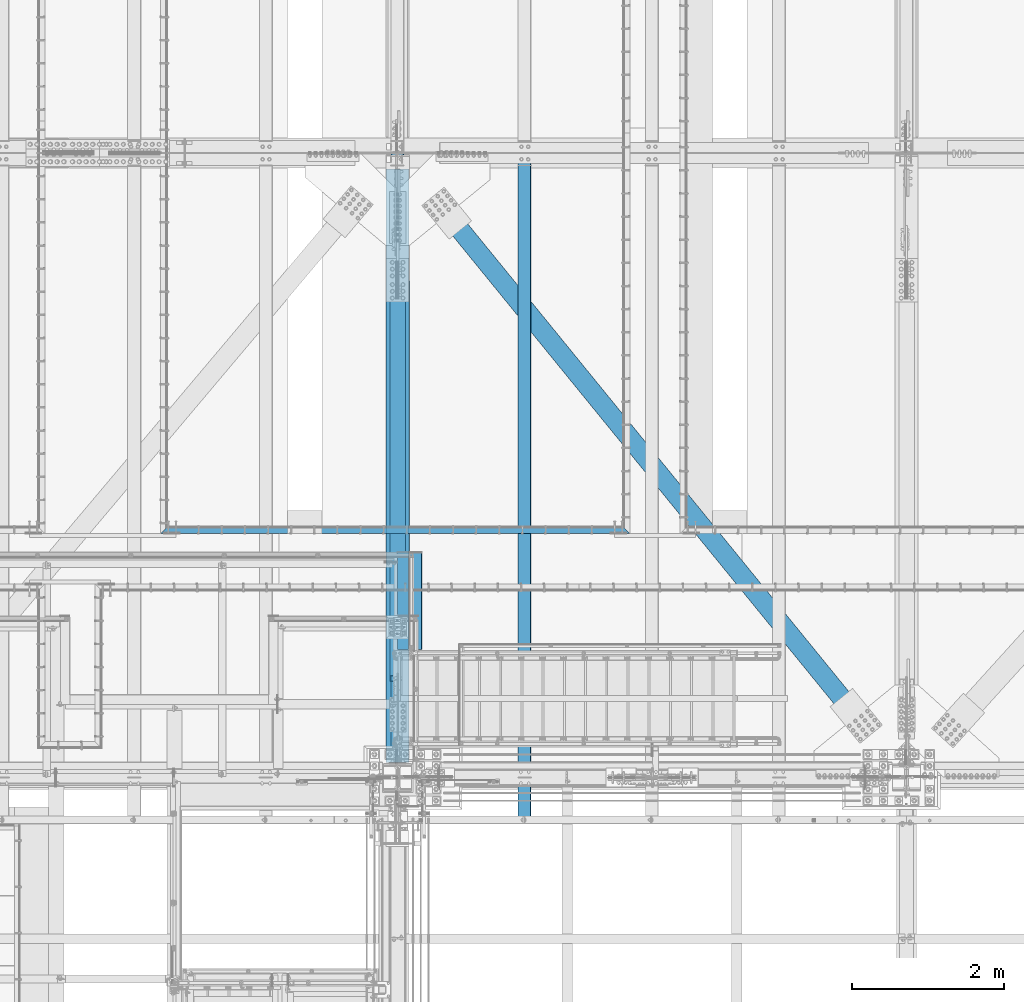
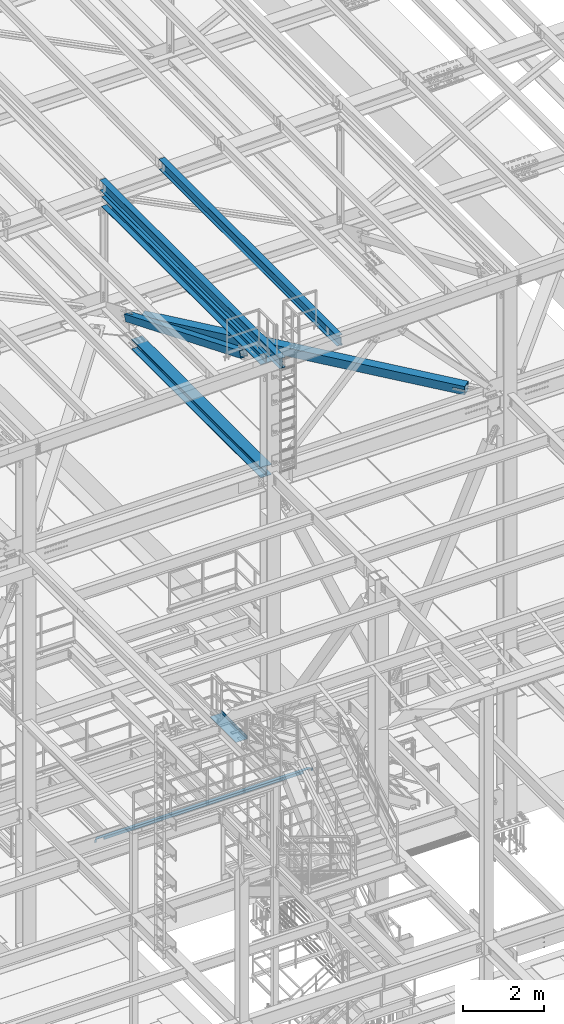
# One storey, part 1791 of 3843: 7 beams, 1 member, 8 elements without a shape of their own.
"""IFC2X3 building model written with IfcOpenShell, lengths in millimetres."""

from ifc_helpers import new_model, si_unit, frame, origin_with_axes, place, context, subcontext, project, spatial, faceted_brep, material, type_object, element, aggregate, save


model = new_model("IFC2X3")

# Units and contexts
model_context = context("Model", 3, precision=1e-05, world=origin_with_axes())
body_context = subcontext(model_context, "Body", "Model", "MODEL_VIEW")
ifc_project = project(units=[si_unit("LENGTHUNIT", "METRE", prefix="MILLI"), si_unit("AREAUNIT", "SQUARE_METRE"), si_unit("VOLUMEUNIT", "CUBIC_METRE"), si_unit("MASSUNIT", "GRAM", prefix="KILO"), si_unit("TIMEUNIT", "SECOND"), si_unit("PLANEANGLEUNIT", "RADIAN"), si_unit("SOLIDANGLEUNIT", "STERADIAN"), si_unit("THERMODYNAMICTEMPERATUREUNIT", "DEGREE_CELSIUS"), si_unit("LUMINOUSINTENSITYUNIT", "LUMEN")], contexts=[model_context])

# Site, building, storey
site_placement = place(None, origin_with_axes())
site = spatial("IfcSite", under=ifc_project, at=site_placement, CompositionType="ELEMENT")
building_placement = place(site_placement, origin_with_axes())
building = spatial("IfcBuilding", under=site, at=building_placement, Name="Undefined", CompositionType="ELEMENT")
storey_placement = place(building_placement, origin_with_axes())
storey = spatial("IfcBuildingStorey", under=building, at=storey_placement, Name="Undefined", CompositionType="ELEMENT", Elevation=0.0)

# Assembly, beam
assembly_1_placement = place(storey_placement, origin_with_axes())
assembly_1 = element("IfcElementAssembly", 1, at=assembly_1_placement, inside=storey, Name="EMBED_ANGLE", AssemblyPlace="NOTDEFINED", PredefinedType="RIGID_FRAME")
ifc_material_1 = material(Name="STEEL/A36")
beam_type_1 = type_object("IfcBeamType", Name="L3-1/2X3-1/2X5/16", PredefinedType="NOTDEFINED")
beam_1_placement = place(assembly_1_placement, frame((52807.362, 28873.45, 30410.15), z_axis=(0.0, 0.0, -1.0), x_axis=(1.0, 0.0, 0.0)))
beam_1 = element("IfcBeam", 2, at=beam_1_placement, type_object=beam_type_1, material=ifc_material_1, Name="EMBED_ANGLE", ObjectType="L3-1/2X3-1/2X5/16", context=body_context, shape_type="Brep", body=[
    faceted_brep([(44.4497890624625, 36.5125000000007, 44.4500000000007), (44.4497890624625, 36.5125000000007, -36.5125000000007), (44.4497890624625, 44.4500000000007, -36.5124999999971), (44.4497890624625, 44.4500000000007, 44.4500000000007), (260.349789062486, 36.5125000000007, -36.5125000000007), (260.349789062486, 44.4500000000007, -36.5125000000007), (260.349789062486, 36.5125000000007, 44.4499999999898), (260.349789062486, 44.4500000000007, 44.4500000000007), (6177.02586035159, 36.5125000000007, 44.4500000000007), (6184.96336035159, 44.4500000000007, 44.4500000000007), (6140.44980468748, 44.4500000000007, 44.4500000000007), (6140.44980468748, 36.5125000000007, 44.4499999999862), (5924.54980468746, 36.5125000000007, -36.5125000000007), (5924.54980468746, 36.5125000000007, 44.4500000000007), (5924.54980468746, 44.4500000000007, -36.5125000000007), (5924.54980468746, 44.4500000000007, 44.4500000000007), (6140.44980468748, 36.5125000000007, -36.5125000000007), (6140.44980468748, 44.4500000000007, -36.5125000000044), (6177.02586035159, 36.5125000000007, -36.5125000000007), (5924.54980468746, -44.4500000000007, -36.5125000000007), (260.349789062486, -44.4500000000007, -36.5125000000007), (88.8989646580376, -44.4500000000007, -36.5125000000007), (88.8989646580376, -44.4500000000007, -44.4500000000007), (6096.06336035159, -44.4500000000007, -44.4500000000007), (6096.06336035159, -44.4500000000007, -36.5125000000007), (44.4497890624625, -0.000305424058751669, -36.5125000000007), (7.93740995020198, 36.5125000000007, -36.5125000000007), (7.93740995020198, 36.5125000000007, 44.4500000000007), (-3.63797880709171e-12, 44.4499999999971, 44.4500000000007), (-3.63797880709171e-12, 44.4499999999971, -44.4500000000007), (6184.96336035159, 44.4500000000007, -44.4500000000007), (6140.44980468748, -0.0635556641136645, -36.5125000000007)], [[[0, 1, 2, 3]], [[4, 5, 2, 1]], [[6, 7, 5, 4]], [[8, 9, 10, 11]], [[12, 13, 6, 4]], [[13, 12, 14, 15]], [[16, 17, 14, 12]], [[11, 10, 17, 16]], [[18, 8, 11, 16]], [[19, 20, 21, 22, 23, 24]], [[22, 21, 25, 26, 27, 28, 29]], [[22, 29, 30, 23]], [[8, 18, 31, 24, 23, 30, 9]], [[16, 12, 4, 1, 26, 25, 21, 20, 19, 24, 31, 18]], [[27, 26, 1, 0]], [[28, 27, 0, 3]], [[15, 14, 17, 10, 9, 30, 29, 28, 3, 2, 5, 7]], [[13, 15, 7, 6]]]),
])
aggregate(assembly_1, [beam_1])

assembly_2_placement = place(storey_placement, origin_with_axes())
assembly_2 = element("IfcElementAssembly", 3, at=assembly_2_placement, inside=storey, Name="BEAM", AssemblyPlace="NOTDEFINED", PredefinedType="RIGID_FRAME")
ifc_material_2 = material(Name="STEEL/A992")
beam_type_2 = type_object("IfcBeamType", Name="W12X26", PredefinedType="NOTDEFINED")
beam_2_placement = place(assembly_2_placement, frame((55927.5092622735, 25006.1356762466, 45983.4013498801), z_axis=(-0.0211520978121262, -0.00105623500043294, 0.999775711410199), x_axis=(0.0, 0.999999441934358, 0.00105647099993039)))
beam_2 = element("IfcBeam", 4, at=beam_2_placement, type_object=beam_type_2, material=ifc_material_2, Name="BEAM", ObjectType="W12X26", context=body_context, shape_type="Brep", body=[
    faceted_brep([(0.0, 82.5500000000029, -155.574999999997), (0.0, 82.5500000000029, -146.050000000003), (8826.51314174311, 82.5499999993626, -146.049999974304), (8826.50308110259, 82.5499999993626, -155.574999974284), (0.0, 3.17500000000291, -146.050000000003), (8826.51491550364, 3.17499999947904, -146.049999974122), (0.0, 3.17500000000291, 146.050000000003), (8826.82344181322, 3.17499999942083, 146.050000024981), (0.0, 82.5500000000029, 146.050000000003), (8826.8216680527, 82.5499999992899, 146.050000024785), (0.0, 82.5500000000029, 155.574999999997), (8826.83172869323, 82.5499999992899, 155.575000024757), (0.0, -82.5500000000029, 155.574999999997), (8826.83541811513, -82.5500000004467, 155.57500002515), (0.0, -82.5500000000029, 146.050000000003), (8826.82535747459, -82.5500000004467, 146.050000025185), (0.0, -3.17500000000291, 146.050000000003), (8826.82358371407, -3.17500000057044, 146.050000024996), (0.0, -3.17500000000291, -146.050000000003), (8826.51505740448, -3.17500000051223, -146.049999974101), (0.0, -82.5500000000029, -146.050000000003), (8826.51683116501, -82.5500000003813, -146.049999973911), (0.0, -82.5500000000029, -155.574999999997), (8826.50677052448, -82.5500000003813, -155.574999973884)], [[[0, 1, 2, 3]], [[1, 4, 5, 2]], [[4, 6, 7, 5]], [[6, 8, 9, 7]], [[8, 10, 11, 9]], [[10, 12, 13, 11]], [[12, 14, 15, 13]], [[14, 16, 17, 15]], [[16, 18, 19, 17]], [[18, 20, 21, 19]], [[20, 22, 23, 21]], [[22, 0, 3, 23]], [[5, 7, 9, 11, 13, 15, 17, 19, 21, 23, 3, 2]], [[22, 20, 18, 16, 14, 12, 10, 8, 6, 4, 1, 0]]]),
])
aggregate(assembly_2, [beam_2])

assembly_3_placement = place(storey_placement, origin_with_axes())
assembly_3 = element("IfcElementAssembly", 5, at=assembly_3_placement, inside=storey, Name="BEAM", AssemblyPlace="NOTDEFINED", PredefinedType="RIGID_FRAME")
beam_3_placement = place(assembly_3_placement, frame((57603.9092622737, 25006.1214434998, 46018.8686464148), z_axis=(-0.0211520979449343, -0.00114771899950938, 0.999775610571505), x_axis=(0.0, 0.999999341075335, 0.0011479760000864)))
beam_3 = element("IfcBeam", 6, at=beam_3_placement, type_object=beam_type_2, material=ifc_material_2, Name="BEAM", ObjectType="W12X26", context=body_context, shape_type="Brep", body=[
    faceted_brep([(20.6667429440167, -3.17500000036671, -130.17499999718), (20.6665887525705, 3.17499999962456, -130.174999997202), (77.7855094644401, 3.17499999962456, -130.174999997689), (77.7855094644401, -3.17500000035943, -130.174999997711), (82.6455889824756, 3.17499999963184, -131.141729920288), (82.6455889824792, -3.17500000036671, -131.141729920309), (86.765765450622, 3.17499999961728, -133.894743820791), (86.7657654506256, -3.17500000036671, -133.894743820812), (89.5187793510886, 3.17499999961001, -138.014920288981), (89.5187793510922, -3.17500000038854, -138.014920289002), (90.4855092736725, -3.17500000039581, -142.874999807093), (90.4855092736689, 3.17499999959546, -142.874999807071), (90.4855092736361, 3.1749999995809, -146.050000000454), (90.4855092736325, 82.5499999994281, -146.050000000432), (90.4855092736252, 82.5499999993917, -155.575000000455), (90.4855092736325, -82.5500000002794, -155.575000000499), (90.4855092736398, -82.5500000002357, -146.050000000461), (90.4855092736361, -3.17500000040309, -146.050000000454), (8826.85400159248, -82.5499999993481, 146.049999996379), (8826.86493362471, -82.549999999319, 155.574999996403), (90.4855092739417, -82.5499999994208, 155.487476279835), (90.4855092739344, -82.5499999994281, 146.050000000359), (8826.86092464718, 82.5500000003522, 155.574999996439), (90.4855092739381, 82.5500000002648, 155.575000000419), (8826.84999261495, 82.5500000003231, 146.049999996409), (90.4855092739308, 82.550000000243, 146.050000000396), (8826.85192000799, 3.17500000048312, 146.049999996394), (90.4855092739308, 3.17500000039581, 146.050000000389), (77.785509464702, -3.17499999963184, 130.175000004041), (77.7855094646984, 3.17500000035216, 130.175000004063), (20.9653976335285, 3.17500000035216, 130.175000004623), (20.965551824971, -3.17499999963184, 130.175000004645), (82.6455889827412, -3.17499999963184, 131.14172992664), (82.6455889827375, 3.17500000035943, 131.141729926661), (86.7657654508876, -3.17499999962456, 133.894743827143), (86.7657654508839, 3.17500000036671, 133.894743827164), (89.5187793513614, -3.17499999961001, 138.014920295325), (89.5187793513578, 3.17500000037398, 138.014920295347), (90.4855092739526, -3.17499999959546, 142.874999813415), (90.4855092739526, 3.17500000038854, 142.874999813437), (90.4855092739308, -3.17499999958818, 146.050000000381), (8826.85207419943, -3.17499999950087, 146.049999996387), (8826.5166710196, 3.17499999966822, -146.050000004441), (8826.51682521103, -3.17500000031578, -146.050000004441), (8826.51875260409, -82.5500000001557, -146.050000004456), (8826.50782057185, -82.5500000001921, -155.575000004486), (8826.50381159433, 82.549999999479, -155.575000004443), (8826.51474362656, 82.5499999995081, -146.050000004427), (20.6861993458151, 3.17499999967549, -113.088433040881), (20.9508633848673, 3.17500000031578, 117.511415083012)], [[[0, 1, 2, 3]], [[3, 2, 4, 5]], [[5, 4, 6, 7]], [[7, 6, 8, 9]], [[10, 11, 12, 13, 14, 15, 16, 17]], [[9, 8, 11, 10]], [[18, 19, 20, 21]], [[19, 22, 23, 20]], [[22, 24, 25, 23]], [[24, 26, 27, 25]], [[28, 29, 30, 31]], [[32, 33, 29, 28]], [[34, 35, 33, 32]], [[36, 37, 35, 34]], [[38, 39, 37, 36]], [[20, 23, 25, 27, 39, 38, 40, 21]], [[41, 18, 21, 40]], [[42, 26, 24, 22, 19, 18, 41, 43, 44, 45, 46, 47]], [[44, 43, 17, 16]], [[45, 44, 16, 15]], [[46, 45, 15, 14]], [[47, 46, 14, 13]], [[42, 47, 13, 12]], [[6, 4, 2, 1, 48, 49, 30, 29, 33, 35, 37, 39, 27, 26, 42, 12, 11, 8]], [[31, 30, 49, 48, 1, 0]], [[43, 41, 40, 38, 36, 34, 32, 28, 31, 0, 3, 5, 7, 9, 10, 17]]]),
])
aggregate(assembly_3, [beam_3])

assembly_4_placement = place(storey_placement, origin_with_axes())
assembly_4 = element("IfcElementAssembly", 7, at=assembly_4_placement, inside=storey, Name="BEAM", AssemblyPlace="NOTDEFINED", PredefinedType="RIGID_FRAME")
beam_type_3 = type_object("IfcBeamType", Name="W12X79", PredefinedType="NOTDEFINED")
beam_4_placement = place(assembly_4_placement, frame((55930.7999999999, 25615.9000000023, 42246.5499979615), z_axis=(0.0, -0.00113550900035625, 0.999999355309447), x_axis=(0.0, 0.999999355309447, 0.00113550900035246)))
beam_4 = element("IfcBeam", 8, at=beam_4_placement, type_object=beam_type_3, material=ifc_material_2, Name="BEAM", ObjectType="W12X79", context=body_context, shape_type="Brep", body=[
    faceted_brep([(197.028586453518, -153.987500000003, -138.112499999108), (197.028586453449, -153.987500000003, -157.162499999053), (6546.85422477993, -153.987500000003, -157.162499983642), (6546.85422478, -153.987500000003, -138.112499983697), (197.028586453518, -6.34999999999854, -138.112499999108), (6546.85422478, -6.34999999999854, -138.112499983697), (197.028586454522, -6.34999999999854, 138.112500000076), (6546.854224781, -6.34999999999854, 138.112500015479), (197.028586454522, -153.987500000003, 138.112500000076), (6546.854224781, -153.987500000003, 138.112500015479), (197.028586454591, -153.987500000003, 157.162500000013), (6546.85422478107, -153.987500000003, 157.162500015431), (197.028586454591, 153.987500000003, 157.162500000013), (6546.85422478107, 153.987500000003, 157.162500015431), (197.028586454522, 153.987500000003, 138.112500000076), (6546.854224781, 153.987500000003, 138.112500015479), (197.028586454522, 6.34999999999854, 138.112500000076), (6546.854224781, 6.34999999999854, 138.112500015479), (197.028586453518, 6.34999999999854, -138.112499999108), (6546.85422478, 6.34999999999854, -138.112499983697), (197.028586453518, 153.987500000003, -138.112499999108), (6546.85422478, 153.987500000003, -138.112499983697), (197.028586453449, 153.987500000003, -157.162499999053), (6546.85422477993, 153.987500000003, -157.162499983642)], [[[0, 1, 2, 3]], [[4, 0, 3, 5]], [[6, 4, 5, 7]], [[8, 6, 7, 9]], [[10, 8, 9, 11]], [[12, 10, 11, 13]], [[14, 12, 13, 15]], [[16, 14, 15, 17]], [[18, 16, 17, 19]], [[20, 18, 19, 21]], [[1, 0, 4, 6, 8, 10, 12, 14, 16, 18, 20, 22]], [[1, 22, 23, 2]], [[19, 17, 15, 13, 11, 9, 7, 5, 3, 2, 23, 21]], [[22, 20, 21, 23]]]),
])
aggregate(assembly_4, [beam_4])

# Assembly, member
assembly_5_placement = place(storey_placement, origin_with_axes())
assembly_5 = element("IfcElementAssembly", 9, at=assembly_5_placement, inside=storey, AssemblyPlace="NOTDEFINED", PredefinedType="RIGID_FRAME")
ifc_material_3 = material()
member_type = type_object("IfcMemberType", Name="HSS8X8X1/2", PredefinedType="NOTDEFINED")
member_placement = place(assembly_5_placement, frame((55930.8, 33845.5, 42255.8947888465), z_axis=(-1.0, 0.0, 0.0), x_axis=(0.0, -0.924846166890431, 0.380341382954942)))
member = element("IfcMember", 10, at=member_placement, type_object=member_type, material=ifc_material_3, ObjectType="HSS8X8X1/2", context=body_context, shape_type="Brep", body=[
    faceted_brep([(1361.43664007557, -101.600000000903, 17.4625000000087), (1361.43664007563, -88.900000000961, 17.4625000000087), (1613.84914047066, -88.9000000012011, 17.4625000000087), (1613.84914047053, -101.600000001147, 17.4625000000087), (1620.53174976245, -88.900000001212, 16.1332463655272), (1620.53174976233, -101.600000001162, 16.1332463655272), (1626.19699236758, -88.900000001212, 12.3478522782098), (1626.19699236746, -101.600000001169, 12.3478522782098), (1629.98238645495, -88.9000000012193, 6.68260967317474), (1629.98238645484, -101.600000001165, 6.68260967317474), (1613.84914047053, -101.600000001147, -17.4624999999942), (1613.84914047066, -88.9000000012011, -17.4624999999942), (1361.43664007563, -88.900000000961, -17.4624999999942), (1361.43664007557, -101.600000000903, -17.4624999999942), (1620.53174976233, -101.600000001162, -16.1332463655126), (1620.53174976245, -88.900000001212, -16.1332463655126), (1626.19699236746, -101.600000001169, -12.3478522781952), (1626.19699236758, -88.900000001212, -12.3478522781952), (1629.98238645484, -101.600000001165, -6.68260967316019), (1629.98238645495, -88.9000000012193, -6.68260967316019), (1631.31164008933, -101.600000001169, 3.81478457711637e-07), (1631.31164008945, -88.9000000012156, 3.81478457711637e-07), (1361.43664007632, 88.8999999982962, 17.4625000000087), (1361.43664007637, 101.599999998242, 17.4625000000087), (1613.84914047235, 101.599999998002, 17.4625000000087), (1613.84914047223, 88.899999998056, 17.4625000000087), (1620.53174976414, 101.599999997991, 16.1332463655272), (1620.53174976402, 88.8999999980379, 16.1332463655272), (1626.19699236925, 101.599999997991, 12.3478522782098), (1626.19699236915, 88.8999999980342, 12.3478522782098), (1629.98238645664, 101.59999999798, 6.68260967317474), (1629.98238645654, 88.8999999980379, 6.68260967317474), (1613.84914047223, 88.899999998056, -17.4624999999942), (1613.84914047235, 101.599999998002, -17.4624999999942), (1361.43664007637, 101.599999998242, -17.4624999999942), (1361.43664007632, 88.8999999982962, -17.4624999999942), (1620.53174976402, 88.8999999980379, -16.1332463655126), (1620.53174976414, 101.599999997991, -16.1332463655126), (1626.19699236915, 88.8999999980342, -12.3478522781952), (1626.19699236925, 101.599999997991, -12.3478522781952), (1629.98238645654, 88.8999999980379, -6.68260967316019), (1629.98238645664, 101.59999999798, -6.68260967316019), (1631.31164009104, 88.8999999980342, 3.81478457711637e-07), (1631.31164009115, 101.599999997984, 3.81478457711637e-07), (1361.43664007563, -88.900000000961, 88.9000000000015), (1361.43664007632, 88.8999999982962, 88.9000000000015), (7488.43481213594, 88.8999999923117, 88.9000000000015), (7488.43481213525, -88.9000000069418, 88.9000000000015), (1361.43664007637, 101.599999998242, 101.599999999999), (7488.43481213599, 101.599999992251, 101.599999999999), (7488.43484353106, 101.599999978956, -6.34999999999854), (7236.02234315402, 101.599999979662, -6.34999999999854), (7229.33973386236, 101.599999979684, -7.67925363448012), (7223.67449125734, 101.599999979706, -11.4646477217975), (7219.88909717004, 101.599999979706, -17.1298903268325), (7218.55984353556, 101.599999979713, -23.8125003814712), (7219.88909717004, 101.599999979706, -30.4951096731675), (7223.67449125734, 101.599999979706, -36.1603522782025), (7229.33973386236, 101.599999979684, -39.9457463655199), (7236.02234315402, 101.599999979662, -41.2750000000015), (7488.43484353106, 101.599999978956, -41.2750000000015), (7488.43481213599, 101.599999992251, -101.599999999999), (1361.43664007637, 101.599999998242, -101.599999999999), (7488.43484353106, 88.8999999789739, -6.34999999999854), (7236.02234315403, 88.899999979687, -6.34999999999854), (7229.33973386236, 88.8999999797015, -7.67925363448012), (7223.67449125734, 88.8999999797161, -11.4646477217975), (7219.88909717005, 88.8999999797306, -17.1298903268325), (7218.55984353556, 88.8999999797234, -23.8125003814712), (7219.88909717005, 88.8999999797306, -30.4951096731675), (7223.67449125734, 88.8999999797161, -36.1603522782025), (7229.33973386236, 88.8999999797015, -39.9457463655199), (7236.02234315403, 88.899999979687, -41.2750000000015), (7488.43484353106, 88.8999999789739, -41.2750000000015), (1361.43664007632, 88.8999999982962, -88.9000000000015), (1361.43664007563, -88.900000000961, -88.9000000000015), (7488.43481213525, -88.9000000069418, -88.9000000000015), (7488.43481213594, 88.8999999923117, -88.9000000000015), (7229.33973386247, -101.600000020066, -7.67925363448012), (7229.33973386246, -88.9000000200831, -7.67925363448012), (7236.02234315414, -88.9000000200977, -6.34999999999854), (7236.02234315414, -101.600000020087, -6.34999999999854), (7223.67449125745, -101.600000020044, -11.4646477217975), (7223.67449125745, -88.9000000200613, -11.4646477217975), (7219.88909717015, -101.600000020044, -17.1298903268325), (7219.88909717015, -88.900000020054, -17.1298903268325), (7218.55984353568, -101.600000020037, -23.8125003814712), (7218.55984353567, -88.900000020054, -23.8125003814712), (7219.88909717015, -101.600000020044, -30.4951096731675), (7219.88909717015, -88.900000020054, -30.4951096731675), (7223.67449125745, -101.600000020044, -36.1603522782025), (7223.67449125745, -88.9000000200613, -36.1603522782025), (7229.33973386247, -101.600000020066, -39.9457463655199), (7229.33973386246, -88.9000000200831, -39.9457463655199), (7236.02234315414, -101.600000020087, -41.2750000000015), (7236.02234315414, -88.9000000200977, -41.2750000000015), (7488.43484353106, -101.600000020786, -41.2750000000015), (7488.43484353106, -88.9000000208107, -41.2750000000015), (7488.43481213519, -101.600000006895, -101.599999999999), (1361.43664007557, -101.600000000903, -101.599999999999), (7488.43484353106, -88.9000000208107, -6.34999999999854), (7488.43484353106, -101.600000020786, -6.34999999999854), (7488.43481213519, -101.600000006895, 101.599999999999), (1361.43664007557, -101.600000000903, 101.599999999999)], [[[0, 1, 2, 3]], [[3, 2, 4, 5]], [[5, 4, 6, 7]], [[7, 6, 8, 9]], [[10, 11, 12, 13]], [[14, 15, 11, 10]], [[16, 17, 15, 14]], [[18, 19, 17, 16]], [[20, 21, 19, 18]], [[9, 8, 21, 20]], [[22, 23, 24, 25]], [[25, 24, 26, 27]], [[27, 26, 28, 29]], [[29, 28, 30, 31]], [[32, 33, 34, 35]], [[36, 37, 33, 32]], [[38, 39, 37, 36]], [[40, 41, 39, 38]], [[42, 43, 41, 40]], [[31, 30, 43, 42]], [[44, 45, 46, 47]], [[28, 26, 24, 23, 48, 49, 50, 51, 52, 53, 54, 55, 56, 57, 58, 59, 60, 61, 62, 34, 33, 37, 39, 41, 43, 30]], [[63, 64, 51, 50]], [[65, 52, 51, 64]], [[66, 53, 52, 65]], [[67, 54, 53, 66]], [[68, 55, 54, 67]], [[69, 56, 55, 68]], [[70, 57, 56, 69]], [[71, 58, 57, 70]], [[72, 59, 58, 71]], [[73, 60, 59, 72]], [[74, 75, 76, 77]], [[78, 79, 80, 81]], [[82, 83, 79, 78]], [[84, 85, 83, 82]], [[86, 87, 85, 84]], [[88, 89, 87, 86]], [[90, 91, 89, 88]], [[92, 93, 91, 90]], [[94, 95, 93, 92]], [[96, 97, 95, 94]], [[98, 61, 60, 73, 77, 76, 97, 96]], [[99, 62, 61, 98]], [[75, 74, 35, 34, 62, 99, 13, 12]], [[6, 4, 2, 1, 44, 47, 100, 80, 79, 83, 85, 87, 89, 91, 93, 95, 97, 76, 75, 12, 11, 15, 17, 19, 21, 8]], [[101, 81, 80, 100]], [[47, 46, 63, 50, 49, 102, 101, 100]], [[48, 103, 102, 49]], [[16, 14, 10, 13, 99, 98, 96, 94, 92, 90, 88, 86, 84, 82, 78, 81, 101, 102, 103, 0, 3, 5, 7, 9, 20, 18]], [[103, 48, 23, 22, 45, 44, 1, 0]], [[38, 36, 32, 35, 74, 77, 73, 72, 71, 70, 69, 68, 67, 66, 65, 64, 63, 46, 45, 22, 25, 27, 29, 31, 42, 40]]]),
])
aggregate(assembly_5, [member])

# Assembly, beam
assembly_6_placement = place(storey_placement, origin_with_axes())
assembly_6 = element("IfcElementAssembly", 11, at=assembly_6_placement, inside=storey, Name="BEAM", AssemblyPlace="NOTDEFINED", PredefinedType="RIGID_FRAME")
beam_type_4 = type_object("IfcBeamType", PredefinedType="NOTDEFINED")
beam_5_placement = place(assembly_6_placement, frame((55930.8, 27946.35, 33200.9749999995), z_axis=(0.0, -1.0, 0.0), x_axis=(1.0, 0.0, 0.0)))
beam_5 = element("IfcBeam", 12, at=beam_5_placement, type_object=beam_type_4, material=ifc_material_1, Name="BENT_PLATE", context=body_context, shape_type="Brep", body=[
    faceted_brep([(0.0, -3.17500000000291, -641.349999999999), (0.0, -3.17500000000291, 641.349999999999), (0.0, 3.17500000000291, 641.349999999999), (0.0, 3.17500000000291, -641.349999999999), (317.499999999993, 3.17500000000291, 641.349999999999), (317.499999999993, 3.17500000000291, -641.349999999999), (323.849999999999, -3.17500000000291, -641.349999999999), (323.849999999999, -3.17500000000291, 641.349999999999), (317.499999999993, 98.4249999999956, 641.349999999999), (317.499999999993, 98.4249999999956, -641.349999999999), (323.849999999999, 98.4249999999956, 641.349999999999), (323.849999999999, 98.4249999999956, -641.349999999999)], [[[0, 1, 2, 3]], [[3, 2, 4, 5]], [[1, 0, 6, 7]], [[5, 4, 8, 9]], [[4, 2, 1, 7, 10, 8]], [[7, 6, 11, 10]], [[6, 0, 3, 5, 9, 11]], [[10, 11, 9, 8]]]),
])
aggregate(assembly_6, [beam_5])

assembly_7_placement = place(storey_placement, origin_with_axes())
assembly_7 = element("IfcElementAssembly", 13, at=assembly_7_placement, inside=storey, AssemblyPlace="NOTDEFINED", PredefinedType="RIGID_FRAME")
beam_type_5 = type_object("IfcBeamType", Name="HSS10X10X3/4", PredefinedType="NOTDEFINED")
beam_6_placement = place(assembly_7_placement, frame((55930.8, 33845.4999998931, 42246.55), z_axis=(0.775234985390331, 0.631672951318049, 0.0), x_axis=(0.631672951318049, -0.77523498539033, 0.0)))
beam_6 = element("IfcBeam", 14, at=beam_6_placement, type_object=beam_type_5, material=ifc_material_3, ObjectType="HSS10X10X3/4", context=body_context, shape_type="Brep", body=[
    faceted_brep([(9560.48373308783, 1.58750000000146, 127.000000012056), (9257.2712334616, 1.58750000000146, 127.000000011678), (9257.27123346157, 1.58750000000146, 107.950000011653), (9560.48373308784, 1.58750000000146, 107.950000012024), (9251.80364377567, 0.499928791716229, 127.000000011678), (9251.80364377564, 0.499928791716229, 107.950000011646), (9247.16844505561, -2.59721197552426, 127.000000011671), (9247.16844505557, -2.59721197552426, 107.950000011639), (9244.07130428834, -7.23241069557116, 127.000000011663), (9244.07130428831, -7.23241069557116, 107.950000011631), (9242.98373308005, -12.6999996185259, 127.000000011663), (9242.98373308002, -12.6999996185259, 107.950000011631), (9244.07130428834, -18.167589304423, 127.000000011663), (9244.07130428831, -18.167589304423, 107.950000011631), (9247.16844505561, -22.8027880244699, 127.000000011671), (9247.16844505557, -22.8027880244699, 107.950000011639), (9251.80364377567, -25.8999287917104, 127.000000011678), (9251.80364377564, -25.8999287917104, 107.950000011646), (9257.2712334616, -26.9874999999956, 127.000000011678), (9257.27123346157, -26.9874999999956, 107.950000011653), (9560.48373308783, -26.9874999999956, 127.000000012056), (9560.48373308784, -26.9874999999956, 107.950000012024), (9560.48373308785, 1.58750000000146, -107.949999988334), (9257.27123346122, 1.58750000000146, -107.949999988712), (9257.2712334612, 1.58750000000146, -126.999999988744), (9560.48373308784, 1.58750000000146, -126.99999998838), (9251.8036437753, 0.499928791716229, -107.949999988727), (9251.80364377527, 0.499928791716229, -126.999999988759), (9247.16844505523, -2.59721197552426, -107.949999988727), (9247.1684450552, -2.59721197552426, -126.999999988759), (9244.07130428797, -7.23241069557116, -107.949999988741), (9244.07130428794, -7.23241069557116, -126.999999988773), (9242.98373307968, -12.6999996185259, -107.949999988727), (9242.98373307965, -12.6999996185259, -126.999999988759), (9244.07130428797, -18.167589304423, -107.949999988741), (9244.07130428794, -18.167589304423, -126.999999988773), (9247.16844505523, -22.8027880244699, -107.949999988727), (9247.1684450552, -22.8027880244699, -126.999999988759), (9251.8036437753, -25.8999287917104, -107.949999988727), (9251.80364377527, -25.8999287917104, -126.999999988759), (9257.27123346122, -26.9874999999956, -107.949999988712), (9257.2712334612, -26.9874999999956, -126.999999988744), (9560.48373308785, -26.9874999999956, -107.949999988334), (9560.48373308784, -26.9874999999956, -126.99999998838), (1055.13624486455, 107.949999999997, 107.950000001496), (1055.13624486455, 107.949999999997, -107.949999998869), (9560.48373308785, 107.949999999997, -107.949999988334), (9560.48373308784, 107.949999999997, 107.950000012024), (9560.48373308784, -107.949999999997, 107.950000012024), (1055.13624486455, -107.949999999997, 107.950000001496), (1055.13624486455, -26.9874999999956, 107.950000001496), (1307.54874448864, -26.9874999999956, 107.950000001802), (1313.01633417456, -25.8999287917104, 107.950000001809), (1317.65153289462, -22.8027880244699, 107.950000001816), (1320.74867366188, -18.167589304423, 107.950000001823), (1321.83624487017, -12.6999996185259, 107.950000001823), (1320.74867366188, -7.23241069557116, 107.950000001823), (1317.65153289462, -2.59721197552426, 107.950000001816), (1313.01633417456, 0.499928791716229, 107.950000001809), (1307.54874448864, 1.58750000000146, 107.950000001802), (1055.13624486455, 1.58750000000146, 107.950000001496), (1055.13624486455, -107.949999999997, -107.949999998869), (9560.48373308785, -107.949999999997, -107.949999988334), (1055.13624486455, 1.58750000000146, -107.949999998869), (1307.54874448889, 1.58750000000146, -107.949999998564), (1313.01633417482, 0.499928791716229, -107.949999998549), (1317.65153289489, -2.59721197552426, -107.949999998549), (1320.74867366215, -7.23241069557116, -107.949999998549), (1321.83624487043, -12.6999996185259, -107.949999998542), (1320.74867366215, -18.167589304423, -107.949999998549), (1317.65153289489, -22.8027880244699, -107.949999998549), (1313.01633417482, -25.8999287917104, -107.949999998549), (1307.54874448889, -26.9874999999956, -107.949999998564), (1055.13624486455, -26.9874999999956, -107.949999998869), (1055.13624486455, 1.58750000000146, -126.999999998901), (1307.54874448892, 1.58750000000146, -126.999999998596), (1313.01633417485, 0.499928791716229, -126.999999998588), (1317.65153289491, -2.59721197552426, -126.999999998581), (1320.74867366217, -7.23241069557116, -126.999999998581), (1321.83624487046, -12.6999996185259, -126.999999998574), (1320.74867366217, -18.167589304423, -126.999999998581), (1317.65153289491, -22.8027880244699, -126.999999998581), (1313.01633417485, -25.8999287917104, -126.999999998588), (1307.54874448892, -26.9874999999956, -126.999999998596), (1055.13624486455, -26.9874999999956, -126.999999998901), (1055.13624486455, -127.0, -126.999999998901), (1055.13624486455, -127.0, 127.000000001521), (1055.13624486455, -26.9874999999956, 127.000000001521), (1307.5487444886, -26.9874999999956, 127.000000001841), (1313.01633417453, -25.8999287917104, 127.000000001841), (1317.6515328946, -22.8027880244699, 127.000000001848), (1320.74867366186, -18.167589304423, 127.000000001848), (1321.83624487015, -12.6999996185259, 127.000000001848), (1320.74867366186, -7.23241069557116, 127.000000001848), (1317.6515328946, -2.59721197552426, 127.000000001848), (1313.01633417453, 0.499928791716229, 127.000000001841), (1307.5487444886, 1.58750000000146, 127.000000001841), (1055.13624486455, 1.58750000000146, 127.000000001521), (1055.13624486455, 127.0, 127.000000001521), (1055.13624486455, 127.0, -126.999999998901), (9560.48373308783, 127.0, 127.000000012056), (9560.48373308784, 127.0, -126.99999998838), (9560.48373308784, -127.0, -126.99999998838), (9560.48373308783, -127.0, 127.000000012056)], [[[0, 1, 2, 3]], [[4, 5, 2, 1]], [[6, 7, 5, 4]], [[8, 9, 7, 6]], [[10, 11, 9, 8]], [[12, 13, 11, 10]], [[14, 15, 13, 12]], [[16, 17, 15, 14]], [[18, 19, 17, 16]], [[20, 21, 19, 18]], [[22, 23, 24, 25]], [[26, 27, 24, 23]], [[28, 29, 27, 26]], [[30, 31, 29, 28]], [[32, 33, 31, 30]], [[34, 35, 33, 32]], [[36, 37, 35, 34]], [[38, 39, 37, 36]], [[40, 41, 39, 38]], [[42, 43, 41, 40]], [[44, 45, 46, 47]], [[48, 49, 50, 51, 52, 53, 54, 55, 56, 57, 58, 59, 60, 44, 47, 3, 2, 5, 7, 9, 11, 13, 15, 17, 19, 21]], [[61, 49, 48, 62]], [[38, 36, 34, 32, 30, 28, 26, 23, 22, 46, 45, 63, 64, 65, 66, 67, 68, 69, 70, 71, 72, 73, 61, 62, 42, 40]], [[63, 74, 75, 64]], [[64, 75, 76, 65]], [[65, 76, 77, 66]], [[66, 77, 78, 67]], [[67, 78, 79, 68]], [[68, 79, 80, 69]], [[69, 80, 81, 70]], [[70, 81, 82, 71]], [[71, 82, 83, 72]], [[72, 83, 84, 73]], [[49, 61, 73, 84, 85, 86, 87, 50]], [[88, 51, 50, 87]], [[89, 52, 51, 88]], [[90, 53, 52, 89]], [[91, 54, 53, 90]], [[92, 55, 54, 91]], [[93, 56, 55, 92]], [[94, 57, 56, 93]], [[95, 58, 57, 94]], [[96, 59, 58, 95]], [[97, 60, 59, 96]], [[98, 99, 74, 63, 45, 44, 60, 97]], [[99, 98, 100, 101]], [[47, 46, 22, 25, 101, 100, 0, 3]], [[102, 85, 84, 83, 82, 81, 80, 79, 78, 77, 76, 75, 74, 99, 101, 25, 24, 27, 29, 31, 33, 35, 37, 39, 41, 43]], [[86, 85, 102, 103]], [[16, 14, 12, 10, 8, 6, 4, 1, 0, 100, 98, 97, 96, 95, 94, 93, 92, 91, 90, 89, 88, 87, 86, 103, 20, 18]], [[103, 102, 43, 42, 62, 48, 21, 20]]]),
])
aggregate(assembly_7, [beam_6])

assembly_8_placement = place(storey_placement, origin_with_axes())
assembly_8 = element("IfcElementAssembly", 15, at=assembly_8_placement, inside=storey, Name="BEAM", AssemblyPlace="NOTDEFINED", PredefinedType="RIGID_FRAME")
beam_type_6 = type_object("IfcBeamType", Name="W12X65", PredefinedType="NOTDEFINED")
beam_7_placement = place(assembly_8_placement, frame((55930.8, 25615.9, 45640.3035239101), z_axis=(0.0, 0.0, 1.0), x_axis=(0.0, 1.0, 0.0)))
beam_7 = element("IfcBeam", 16, at=beam_7_placement, type_object=beam_type_6, material=ifc_material_2, Name="BEAM", ObjectType="W12X65", context=body_context, shape_type="Brep", body=[
    faceted_brep([(196.849999999165, -152.400000000001, -138.112500000003), (196.849999999165, -152.400000000001, -153.987500000003), (8016.87499999944, -152.399999999994, -153.987500000003), (8016.87499999944, -152.399999999994, -138.112500000003), (196.849999999165, -4.76249999999709, -138.112500000003), (8016.87499999944, -4.76249999999709, -138.112500000003), (196.849999999165, -4.76249999999709, 138.112500000003), (8016.87499999944, -4.76249999999709, 138.112500000003), (196.849999999165, -152.400000000001, 138.112500000003), (8016.87499999944, -152.399999999994, 138.112500000003), (196.849999999165, -152.400000000001, 153.987500000003), (8016.87499999944, -152.399999999994, 153.987500000003), (196.849999999165, 152.400000000001, 153.987500000003), (8016.87499999944, 152.399999999994, 153.987500000003), (196.849999999165, 152.400000000001, 138.112500000003), (8016.87499999944, 152.399999999994, 138.112500000003), (196.849999999165, 4.76249999999709, 138.112500000003), (8016.87499999944, 4.76249999999709, 138.112500000003), (196.849999999165, 4.76249999999709, -138.112500000003), (8016.87499999944, 4.76249999999709, -138.112500000003), (196.849999999165, 152.400000000001, -138.112500000003), (8016.87499999944, 152.399999999994, -138.112500000003), (196.849999999165, 152.400000000001, -153.987500000003), (8016.87499999944, 152.399999999994, -153.987500000003)], [[[0, 1, 2, 3]], [[4, 0, 3, 5]], [[6, 4, 5, 7]], [[8, 6, 7, 9]], [[10, 8, 9, 11]], [[12, 10, 11, 13]], [[14, 12, 13, 15]], [[16, 14, 15, 17]], [[18, 16, 17, 19]], [[20, 18, 19, 21]], [[1, 0, 4, 6, 8, 10, 12, 14, 16, 18, 20, 22]], [[1, 22, 23, 2]], [[19, 17, 15, 13, 11, 9, 7, 5, 3, 2, 23, 21]], [[22, 20, 21, 23]]]),
])
aggregate(assembly_8, [beam_7])

save(model, "model.ifc")
